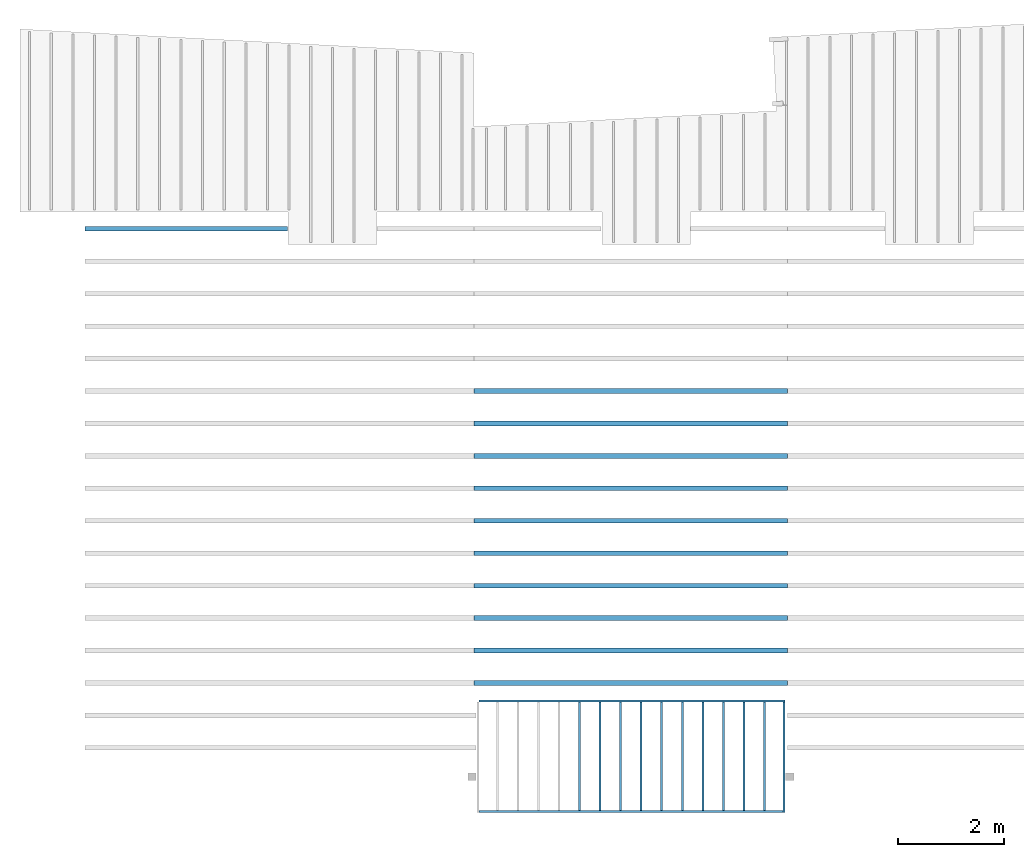
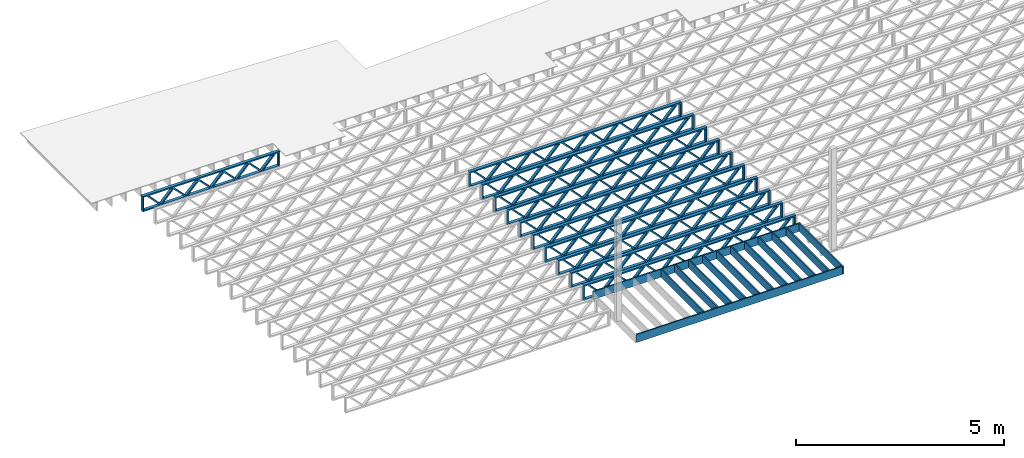
# One storey, part 2 of 13: 24 beams, 3 elements without a shape of their own.
"""IFC4 building model written with IfcOpenShell, lengths in feet."""

from ifc_helpers import new_model, entity, si_unit, converted_unit, derived_unit, direction, frame, frame_2d, origin, origin_2d_with_axis, place, context, subcontext, project, spatial, rectangle, extrude, source, transform, mapped, material, material_profile, profile_set, profile_usage, type_object, type_shapes, element, aggregate, save


model = new_model("IFC4")

# Units and contexts
model_context_1 = context("Model", 3, precision=0.0001, world=origin(), true_north=direction((6.12303176911189e-17, 1.0)))
model_context_2 = context("Model", 3, precision=0.0001, world=origin(), true_north=direction((6.12303176911189e-17, 1.0)))
body_context = subcontext(model_context_2, "Body", "Model", "MODEL_VIEW")
ifc_project = project(units=[converted_unit("LENGTHUNIT", "FOOT", entity("IfcRatioMeasure", 0.3048), si_unit("LENGTHUNIT", "METRE"), dimensions=[1, 0, 0, 0, 0, 0, 0]), converted_unit("AREAUNIT", "SQUARE FOOT", entity("IfcRatioMeasure", 0.09290304), si_unit("AREAUNIT", "SQUARE_METRE"), dimensions=[2, 0, 0, 0, 0, 0, 0]), converted_unit("VOLUMEUNIT", "CUBIC FOOT", entity("IfcRatioMeasure", 0.028316846592), si_unit("VOLUMEUNIT", "CUBIC_METRE"), dimensions=[3, 0, 0, 0, 0, 0, 0]), converted_unit("PLANEANGLEUNIT", "DEGREE", entity("IfcRatioMeasure", 0.0174532925199433), si_unit("PLANEANGLEUNIT", "RADIAN"), dimensions=[0, 0, 0, 0, 0, 0, 0]), si_unit("MASSUNIT", "GRAM", prefix="KILO"), derived_unit("MASSDENSITYUNIT", [(si_unit("MASSUNIT", "GRAM", prefix="KILO"), 1), (si_unit("LENGTHUNIT", "METRE"), -3)]), derived_unit("MOMENTOFINERTIAUNIT", [(si_unit("LENGTHUNIT", "METRE"), 4)]), si_unit("TIMEUNIT", "SECOND"), si_unit("FREQUENCYUNIT", "HERTZ"), si_unit("THERMODYNAMICTEMPERATUREUNIT", "DEGREE_CELSIUS"), derived_unit("THERMALTRANSMITTANCEUNIT", [(si_unit("MASSUNIT", "GRAM", prefix="KILO"), 1), (si_unit("THERMODYNAMICTEMPERATUREUNIT", "KELVIN"), -1), (si_unit("TIMEUNIT", "SECOND"), -3)]), derived_unit("VOLUMETRICFLOWRATEUNIT", [(si_unit("LENGTHUNIT", "METRE"), 3), (si_unit("TIMEUNIT", "SECOND"), -1)]), si_unit("ELECTRICCURRENTUNIT", "AMPERE"), si_unit("ELECTRICVOLTAGEUNIT", "VOLT"), si_unit("POWERUNIT", "WATT"), si_unit("FORCEUNIT", "NEWTON"), si_unit("ILLUMINANCEUNIT", "LUX"), si_unit("LUMINOUSFLUXUNIT", "LUMEN"), si_unit("LUMINOUSINTENSITYUNIT", "CANDELA"), derived_unit("USERDEFINED", [(si_unit("MASSUNIT", "GRAM", prefix="KILO"), -1), (si_unit("LENGTHUNIT", "METRE"), -2), (si_unit("TIMEUNIT", "SECOND"), 3), (si_unit("LUMINOUSFLUXUNIT", "LUMEN"), 1)]), derived_unit("LINEARVELOCITYUNIT", [(si_unit("LENGTHUNIT", "METRE"), 1), (si_unit("TIMEUNIT", "SECOND"), -1)]), si_unit("PRESSUREUNIT", "PASCAL"), derived_unit("USERDEFINED", [(si_unit("LENGTHUNIT", "METRE"), -2), (si_unit("MASSUNIT", "GRAM", prefix="KILO"), 1), (si_unit("TIMEUNIT", "SECOND"), -2)]), derived_unit("LINEARFORCEUNIT", [(si_unit("MASSUNIT", "GRAM", prefix="KILO"), 1), (si_unit("LENGTHUNIT", "METRE"), 1), (si_unit("TIMEUNIT", "SECOND"), -2), (si_unit("LENGTHUNIT", "METRE"), -1)]), derived_unit("PLANARFORCEUNIT", [(si_unit("MASSUNIT", "GRAM", prefix="KILO"), 1), (si_unit("LENGTHUNIT", "METRE"), 1), (si_unit("TIMEUNIT", "SECOND"), -2), (si_unit("LENGTHUNIT", "METRE"), -2)])], contexts=[model_context_1])

# Site, building, storey
site_placement = place(None, origin())
site = spatial("IfcSite", under=ifc_project, at=site_placement, CompositionType="ELEMENT")
building_placement = place(site_placement, origin())
building = spatial("IfcBuilding", under=site, at=building_placement, CompositionType="ELEMENT")
storey_placement = place(building_placement, frame((0.0, 0.0, 21.46875)))
storey = spatial("IfcBuildingStorey", under=building, at=storey_placement, Name="3RD FLOOR", CompositionType="ELEMENT", Elevation=21.46875)

# Assembly, beams
assembly_1_placement = place(storey_placement, origin())
assembly_1 = element("IfcElementAssembly", 1, at=assembly_1_placement, inside=storey, Name="Structural Beam System:Structural Framing System", ObjectType="Structural Beam System:Structural Framing System", AssemblyPlace="NOTDEFINED", PredefinedType="BEAM_GRID")
ifc_material_1 = material(Name="WOOD TRUSS", Category="Materials")
ifc_material_profile_1 = material_profile(ifc_material_1, rectangle(XDim=1.73473973950632, YDim=0.125, at=frame_2d((-1.11022302462516e-16, 8.32667268468867e-17), x_axis=(1.0, 0.0))))
ifc_material_profile_2 = material_profile(ifc_material_1, rectangle(XDim=1.73473973950633, YDim=0.125, at=frame_2d((-1.11022302462516e-16, 8.32667268468867e-17), x_axis=(1.0, 0.0))))
ifc_material_profile_3 = material_profile(ifc_material_1, rectangle(XDim=1.73473973950632, YDim=0.125, at=frame_2d((-5.55111512312578e-17, 1.38777878078145e-16), x_axis=(1.0, 0.0))))
ifc_material_profile_4 = material_profile(ifc_material_1, rectangle(XDim=1.73473973950633, YDim=0.125, at=frame_2d((-1.11022302462516e-16, 8.32667268468867e-17), x_axis=(1.0, 0.0))))
ifc_material_profile_5 = material_profile(ifc_material_1, rectangle(XDim=1.73473973950632, YDim=0.125, at=frame_2d((-1.11022302462516e-16, 8.32667268468867e-17), x_axis=(1.0, 0.0))))
ifc_material_profile_6 = material_profile(ifc_material_1, rectangle(XDim=1.73473973950633, YDim=0.125, at=frame_2d((-2.77555756156289e-16, 3.05311331771918e-16), x_axis=(1.0, 0.0))))
ifc_material_profile_7 = material_profile(ifc_material_1, rectangle(XDim=1.73473973950632, YDim=0.124999999999999, at=frame_2d((-3.88578058618805e-16, -2.4980018054066e-16), x_axis=(1.0, 0.0))))
ifc_material_profile_8 = material_profile(ifc_material_1, rectangle(XDim=1.73473973950633, YDim=0.125, at=frame_2d((2.77555756156289e-16, -3.05311331771918e-16), x_axis=(1.0, 0.0))))
ifc_material_profile_9 = material_profile(ifc_material_1, rectangle(XDim=1.73473973950632, YDim=0.124999999999999, at=frame_2d((-1.11022302462516e-16, 8.32667268468867e-17), x_axis=(1.0, 0.0))))
ifc_material_profile_10 = material_profile(ifc_material_1, rectangle(XDim=1.73473973950633, YDim=0.125, at=origin_2d_with_axis()))
ifc_material_profile_11 = material_profile(ifc_material_1, rectangle(XDim=0.124999999999982, YDim=0.291666666666668, at=origin_2d_with_axis()))
ifc_material_profile_12 = material_profile(ifc_material_1, rectangle(XDim=0.124999999999932, YDim=0.291666666666664, at=origin_2d_with_axis()))
ifc_material_profile_13 = material_profile(ifc_material_1, rectangle(XDim=1.25000000000002, YDim=0.29166666666667, at=origin_2d_with_axis()))
ifc_material_profile_14 = material_profile(ifc_material_1, rectangle(XDim=1.25000000000004, YDim=0.291666666666667, at=origin_2d_with_axis()))
ifc_profile_set_1 = profile_set([ifc_material_profile_1, ifc_material_profile_2, ifc_material_profile_3, ifc_material_profile_4, ifc_material_profile_5, ifc_material_profile_6, ifc_material_profile_7, ifc_material_profile_8, ifc_material_profile_9, ifc_material_profile_10, ifc_material_profile_11, ifc_material_profile_12, ifc_material_profile_13, ifc_material_profile_14])
ifc_profile_usage_1 = profile_usage(ifc_profile_set_1, cardinal=8)
beam_type_1 = type_object("IfcBeamType", PredefinedType="BEAM", material=ifc_profile_set_1)
shared_shape_1 = source(origin(), body_context, "Body", "SweptSolid", [
    extrude(rectangle(XDim=1.73473973950632, YDim=0.124999999999999, at=frame_2d((5.55111512312578e-16, 7.21644966006352e-16), x_axis=(1.0, 0.0))), frame((5.95847627016997, -0.145833333333334, 0.0), z_axis=(0.0, 1.0, 0.0), x_axis=(0.693383046997606, 0.0, 0.720569184836762)), (0.0, 0.0, 1.0), 0.291666666666667),
    extrude(rectangle(XDim=1.73473973950633, YDim=0.125, at=origin_2d_with_axis()), frame((4.7081903964967, -0.145833333333334, 0.0), z_axis=(0.0, 1.0, 0.0), x_axis=(0.69338304699761, 0.0, -0.720569184836758)), (0.0, 0.0, 1.0), 0.291666666666666),
    extrude(rectangle(XDim=1.73473973950632, YDim=0.125, at=frame_2d((2.22044604925031e-16, 3.88578058618805e-16), x_axis=(1.0, 0.0))), frame((3.29180960350347, -0.145833333333334, 0.0), z_axis=(0.0, 1.0, 0.0), x_axis=(0.693383046997606, 0.0, 0.720569184836762)), (0.0, 0.0, 1.0), 0.291666666666667),
    extrude(rectangle(XDim=1.73473973950633, YDim=0.125, at=frame_2d((1.11022302462516e-16, -8.32667268468867e-17), x_axis=(1.0, 0.0))), frame((2.0415237298302, -0.145833333333334, 0.0), z_axis=(0.0, 1.0, 0.0), x_axis=(0.69338304699761, 0.0, -0.720569184836758)), (0.0, 0.0, 1.0), 0.291666666666667),
    extrude(rectangle(XDim=1.73473973950632, YDim=0.125, at=frame_2d((-5.55111512312578e-17, 1.38777878078145e-16), x_axis=(1.0, 0.0))), frame((0.625142936836964, -0.145833333333334, 0.0), z_axis=(0.0, 1.0, 0.0), x_axis=(0.693383046997606, 0.0, 0.720569184836762)), (0.0, 0.0, 1.0), 0.291666666666667),
    extrude(rectangle(XDim=1.73473973950633, YDim=0.125, at=frame_2d((-1.11022302462516e-16, 8.32667268468867e-17), x_axis=(1.0, 0.0))), frame((-0.625142936836306, -0.145833333333334, 0.0), z_axis=(0.0, 1.0, 0.0), x_axis=(0.69338304699761, 0.0, -0.720569184836758)), (0.0, 0.0, 1.0), 0.291666666666667),
    extrude(rectangle(XDim=1.73473973950632, YDim=0.125, at=frame_2d((-1.11022302462516e-16, 8.32667268468867e-17), x_axis=(1.0, 0.0))), frame((-2.04152372982954, -0.145833333333334, 0.0), z_axis=(0.0, 1.0, 0.0), x_axis=(0.693383046997606, 0.0, 0.720569184836762)), (0.0, 0.0, 1.0), 0.291666666666667),
    extrude(rectangle(XDim=1.73473973950633, YDim=0.125, at=origin_2d_with_axis()), frame((-3.29180960350281, -0.145833333333334, 0.0), z_axis=(0.0, 1.0, 0.0), x_axis=(0.69338304699761, 0.0, -0.720569184836758)), (0.0, 0.0, 1.0), 0.291666666666667),
    extrude(rectangle(XDim=1.73473973950632, YDim=0.124999999999999, at=frame_2d((-1.11022302462516e-16, 8.32667268468867e-17), x_axis=(1.0, 0.0))), frame((-4.70819039649604, -0.145833333333334, 0.0), z_axis=(0.0, 1.0, 0.0), x_axis=(0.693383046997606, 0.0, 0.720569184836762)), (0.0, 0.0, 1.0), 0.291666666666667),
    extrude(rectangle(XDim=1.73473973950633, YDim=0.125, at=frame_2d((-5.55111512312578e-16, 6.38378239159465e-16), x_axis=(1.0, 0.0))), frame((-5.95847627016931, -0.145833333333334, 0.0), z_axis=(0.0, 1.0, 0.0), x_axis=(0.69338304699761, 0.0, -0.720569184836758)), (0.0, 0.0, 1.0), 0.291666666666666),
    extrude(rectangle(XDim=1.73473973950632, YDim=0.125, at=frame_2d((-7.21644966006352e-16, -5.82867087928207e-16), x_axis=(1.0, 0.0))), frame((8.62514293683647, -0.145833333333334, 0.0), z_axis=(0.0, 1.0, 0.0), x_axis=(0.693383046997607, 0.0, 0.720569184836761)), (0.0, 0.0, 1.0), 0.291666666666667),
    extrude(rectangle(XDim=1.73473973950633, YDim=0.125, at=origin_2d_with_axis()), frame((7.3748570631632, -0.145833333333334, 0.0), z_axis=(0.0, 1.0, 0.0), x_axis=(0.69338304699761, 0.0, -0.720569184836758)), (0.0, 0.0, 1.0), 0.291666666666666),
    extrude(rectangle(XDim=1.73473973950632, YDim=0.124999999999999, at=frame_2d((-1.11022302462516e-16, 8.32667268468867e-17), x_axis=(1.0, 0.0))), frame((-7.37485706316255, -0.145833333333334, 0.0), z_axis=(0.0, 1.0, 0.0), x_axis=(0.693383046997606, 0.0, 0.720569184836762)), (0.0, 0.0, 1.0), 0.291666666666667),
    extrude(rectangle(XDim=1.73473973950633, YDim=0.125, at=origin_2d_with_axis()), frame((-8.62514293683582, -0.145833333333334, 0.0), z_axis=(0.0, 1.0, 0.0), x_axis=(0.69338304699761, 0.0, -0.720569184836758)), (0.0, 0.0, 1.0), 0.291666666666666),
    extrude(rectangle(XDim=0.124999999999982, YDim=0.291666666666668, at=origin_2d_with_axis()), frame((-9.66666666666609, 0.0, 0.687500000000054), z_axis=(1.0, 0.0, 0.0), x_axis=(0.0, 0.0, -1.0)), (0.0, 0.0, 1.0), 19.3333333333322),
    extrude(rectangle(XDim=0.124999999999932, YDim=0.291666666666664, at=origin_2d_with_axis()), frame((-9.66666666666588, 0.0, -0.687499999999984), z_axis=(1.0, 0.0, 0.0), x_axis=(0.0, 0.0, -1.0)), (0.0, 0.0, 1.0), 19.333333333332),
    extrude(rectangle(XDim=1.25000000000002, YDim=0.29166666666667, at=origin_2d_with_axis()), frame((9.54166666666607, 0.0, 0.0), z_axis=(1.0, 0.0, 0.0), x_axis=(0.0, 0.0, -1.0)), (0.0, 0.0, 1.0), 0.12500000000002),
    extrude(rectangle(XDim=1.25000000000004, YDim=0.291666666666667, at=origin_2d_with_axis()), frame((-9.66666666666609, 0.0, 0.0), z_axis=(1.0, 0.0, 0.0), x_axis=(0.0, 0.0, -1.0)), (0.0, 0.0, 1.0), 0.125000000000023),
])
type_shapes(beam_type_1, [shared_shape_1])
beam_1_placement = place(assembly_1_placement, frame((-232.071493788724, 947.861934882651, -0.947916666666661)))
beam_1 = element("IfcBeam", 2, at=beam_1_placement, type_object=beam_type_1, material=ifc_profile_usage_1, PredefinedType="BEAM", context=body_context, shape_type="MappedRepresentation", body=[
    mapped(shared_shape_1, transform((0.0, 0.0, 0.0), scale=1.0)),
])
ifc_profile_usage_2 = profile_usage(ifc_profile_set_1, cardinal=8)
beam_2_placement = place(assembly_1_placement, frame((-232.071493788724, 945.861934882651, -0.947916666666661)))
beam_2 = element("IfcBeam", 3, at=beam_2_placement, type_object=beam_type_1, material=ifc_profile_usage_2, PredefinedType="BEAM", context=body_context, shape_type="MappedRepresentation", body=[
    mapped(shared_shape_1, transform((0.0, 0.0, 0.0), scale=1.0)),
])
ifc_profile_usage_3 = profile_usage(ifc_profile_set_1, cardinal=8)
beam_3_placement = place(assembly_1_placement, frame((-232.071493788724, 943.861934882651, -0.947916666666661)))
beam_3 = element("IfcBeam", 4, at=beam_3_placement, type_object=beam_type_1, material=ifc_profile_usage_3, PredefinedType="BEAM", context=body_context, shape_type="MappedRepresentation", body=[
    mapped(shared_shape_1, transform((0.0, 0.0, 0.0), scale=1.0)),
])
ifc_profile_usage_4 = profile_usage(ifc_profile_set_1, cardinal=8)
beam_4_placement = place(assembly_1_placement, frame((-232.071493788724, 941.861934882651, -0.947916666666661)))
beam_4 = element("IfcBeam", 5, at=beam_4_placement, type_object=beam_type_1, material=ifc_profile_usage_4, PredefinedType="BEAM", context=body_context, shape_type="MappedRepresentation", body=[
    mapped(shared_shape_1, transform((0.0, 0.0, 0.0), scale=1.0)),
])
ifc_profile_usage_5 = profile_usage(ifc_profile_set_1, cardinal=8)
beam_5_placement = place(assembly_1_placement, frame((-232.071493788724, 939.861934882651, -0.947916666666661)))
beam_5 = element("IfcBeam", 6, at=beam_5_placement, type_object=beam_type_1, material=ifc_profile_usage_5, PredefinedType="BEAM", context=body_context, shape_type="MappedRepresentation", body=[
    mapped(shared_shape_1, transform((0.0, 0.0, 0.0), scale=1.0)),
])
ifc_profile_usage_6 = profile_usage(ifc_profile_set_1, cardinal=8)
beam_6_placement = place(assembly_1_placement, frame((-232.071493788724, 937.861934882651, -0.947916666666661)))
beam_6 = element("IfcBeam", 7, at=beam_6_placement, type_object=beam_type_1, material=ifc_profile_usage_6, PredefinedType="BEAM", context=body_context, shape_type="MappedRepresentation", body=[
    mapped(shared_shape_1, transform((0.0, 0.0, 0.0), scale=1.0)),
])
ifc_profile_usage_7 = profile_usage(ifc_profile_set_1, cardinal=8)
beam_7_placement = place(assembly_1_placement, frame((-232.071493788724, 935.861934882651, -0.947916666666661)))
beam_7 = element("IfcBeam", 8, at=beam_7_placement, type_object=beam_type_1, material=ifc_profile_usage_7, PredefinedType="BEAM", context=body_context, shape_type="MappedRepresentation", body=[
    mapped(shared_shape_1, transform((0.0, 0.0, 0.0), scale=1.0)),
])
ifc_profile_usage_8 = profile_usage(ifc_profile_set_1, cardinal=8)
beam_8_placement = place(assembly_1_placement, frame((-232.071493788724, 933.861934882651, -0.947916666666661)))
beam_8 = element("IfcBeam", 9, at=beam_8_placement, type_object=beam_type_1, material=ifc_profile_usage_8, PredefinedType="BEAM", context=body_context, shape_type="MappedRepresentation", body=[
    mapped(shared_shape_1, transform((0.0, 0.0, 0.0), scale=1.0)),
])
ifc_profile_usage_9 = profile_usage(ifc_profile_set_1, cardinal=8)
beam_9_placement = place(assembly_1_placement, frame((-232.071493788724, 931.861934882651, -0.947916666666661)))
beam_9 = element("IfcBeam", 10, at=beam_9_placement, type_object=beam_type_1, material=ifc_profile_usage_9, PredefinedType="BEAM", context=body_context, shape_type="MappedRepresentation", body=[
    mapped(shared_shape_1, transform((0.0, 0.0, 0.0), scale=1.0)),
])
ifc_profile_usage_10 = profile_usage(ifc_profile_set_1, cardinal=8)
beam_10_placement = place(assembly_1_placement, frame((-232.071493788724, 929.861934882651, -0.947916666666661)))
beam_10 = element("IfcBeam", 11, at=beam_10_placement, type_object=beam_type_1, material=ifc_profile_usage_10, PredefinedType="BEAM", context=body_context, shape_type="MappedRepresentation", body=[
    mapped(shared_shape_1, transform((0.0, 0.0, 0.0), scale=1.0)),
])
aggregate(assembly_1, [beam_1, beam_2, beam_3, beam_4, beam_5, beam_6, beam_7, beam_8, beam_9, beam_10])

# Assembly, beam
assembly_2_placement = place(storey_placement, origin())
assembly_2 = element("IfcElementAssembly", 12, at=assembly_2_placement, inside=storey, Name="Structural Beam System:Structural Framing System", ObjectType="Structural Beam System:Structural Framing System", AssemblyPlace="NOTDEFINED", PredefinedType="BEAM_GRID")
ifc_profile_usage_11 = profile_usage(ifc_profile_set_1, cardinal=8)
beam_type_2 = type_object("IfcBeamType", PredefinedType="BEAM", material=ifc_profile_set_1)
shared_shape_2 = source(origin(), body_context, "Body", "SweptSolid", [
    extrude(rectangle(XDim=1.73473973950632, YDim=0.125, at=frame_2d((-1.11022302462516e-16, 8.32667268468867e-17), x_axis=(1.0, 0.0))), frame((2.91681155651982, -0.145833333333334, 0.0), z_axis=(0.0, 1.0, 0.0), x_axis=(0.693383046997606, 0.0, 0.720569184836762)), (0.0, 0.0, 1.0), 0.291666666666667),
    extrude(rectangle(XDim=1.73473973950633, YDim=0.125, at=frame_2d((-1.11022302462516e-16, 8.32667268468867e-17), x_axis=(1.0, 0.0))), frame((1.66652568284655, -0.145833333333334, 0.0), z_axis=(0.0, 1.0, 0.0), x_axis=(0.69338304699761, 0.0, -0.720569184836758)), (0.0, 0.0, 1.0), 0.291666666666667),
    extrude(rectangle(XDim=1.73473973950632, YDim=0.125, at=frame_2d((-5.55111512312578e-17, 1.38777878078145e-16), x_axis=(1.0, 0.0))), frame((0.625142936836964, -0.145833333333334, 0.0), z_axis=(0.0, 1.0, 0.0), x_axis=(0.693383046997606, 0.0, 0.720569184836762)), (0.0, 0.0, 1.0), 0.291666666666667),
    extrude(rectangle(XDim=1.73473973950633, YDim=0.125, at=frame_2d((-1.11022302462516e-16, 8.32667268468867e-17), x_axis=(1.0, 0.0))), frame((-0.625142936836307, -0.145833333333334, 0.0), z_axis=(0.0, 1.0, 0.0), x_axis=(0.69338304699761, 0.0, -0.720569184836758)), (0.0, 0.0, 1.0), 0.291666666666667),
    extrude(rectangle(XDim=1.73473973950632, YDim=0.125, at=frame_2d((-1.11022302462516e-16, 8.32667268468867e-17), x_axis=(1.0, 0.0))), frame((-1.66652568284589, -0.145833333333334, 0.0), z_axis=(0.0, 1.0, 0.0), x_axis=(0.693383046997606, 0.0, 0.720569184836762)), (0.0, 0.0, 1.0), 0.291666666666667),
    extrude(rectangle(XDim=1.73473973950633, YDim=0.125, at=frame_2d((-2.77555756156289e-16, 3.05311331771918e-16), x_axis=(1.0, 0.0))), frame((-2.91681155651916, -0.145833333333334, 0.0), z_axis=(0.0, 1.0, 0.0), x_axis=(0.69338304699761, 0.0, -0.720569184836758)), (0.0, 0.0, 1.0), 0.291666666666667),
    extrude(rectangle(XDim=1.73473973950632, YDim=0.124999999999999, at=frame_2d((-3.88578058618805e-16, -2.4980018054066e-16), x_axis=(1.0, 0.0))), frame((5.20848017620267, -0.145833333333334, 0.0), z_axis=(0.0, 1.0, 0.0), x_axis=(0.693383046997607, 0.0, 0.720569184836761)), (0.0, 0.0, 1.0), 0.291666666666666),
    extrude(rectangle(XDim=1.73473973950633, YDim=0.125, at=frame_2d((2.77555756156289e-16, -3.05311331771918e-16), x_axis=(1.0, 0.0))), frame((3.9581943025294, -0.145833333333334, 0.0), z_axis=(0.0, 1.0, 0.0), x_axis=(0.69338304699761, 0.0, -0.720569184836758)), (0.0, 0.0, 1.0), 0.291666666666666),
    extrude(rectangle(XDim=1.73473973950632, YDim=0.124999999999999, at=frame_2d((-1.11022302462516e-16, 8.32667268468867e-17), x_axis=(1.0, 0.0))), frame((-3.95819430252874, -0.145833333333334, 0.0), z_axis=(0.0, 1.0, 0.0), x_axis=(0.693383046997606, 0.0, 0.720569184836762)), (0.0, 0.0, 1.0), 0.291666666666667),
    extrude(rectangle(XDim=1.73473973950633, YDim=0.125, at=origin_2d_with_axis()), frame((-5.20848017620202, -0.145833333333334, 0.0), z_axis=(0.0, 1.0, 0.0), x_axis=(0.69338304699761, 0.0, -0.720569184836758)), (0.0, 0.0, 1.0), 0.291666666666666),
    extrude(rectangle(XDim=0.124999999999982, YDim=0.291666666666668, at=origin_2d_with_axis()), frame((-6.25000390603229, 0.0, 0.687500000000054), z_axis=(1.0, 0.0, 0.0), x_axis=(0.0, 0.0, -1.0)), (0.0, 0.0, 1.0), 12.5000078120646),
    extrude(rectangle(XDim=0.124999999999932, YDim=0.291666666666664, at=origin_2d_with_axis()), frame((-6.25000390603208, 0.0, -0.687499999999984), z_axis=(1.0, 0.0, 0.0), x_axis=(0.0, 0.0, -1.0)), (0.0, 0.0, 1.0), 12.5000078120644),
    extrude(rectangle(XDim=1.25000000000002, YDim=0.29166666666667, at=origin_2d_with_axis()), frame((6.12500390603227, 0.0, 0.0), z_axis=(1.0, 0.0, 0.0), x_axis=(0.0, 0.0, -1.0)), (0.0, 0.0, 1.0), 0.12500000000002),
    extrude(rectangle(XDim=1.25000000000004, YDim=0.291666666666667, at=origin_2d_with_axis()), frame((-6.25000390603229, 0.0, 0.0), z_axis=(1.0, 0.0, 0.0), x_axis=(0.0, 0.0, -1.0)), (0.0, 0.0, 1.0), 0.125000000000023),
])
type_shapes(beam_type_2, [shared_shape_2])
beam_11_placement = place(assembly_2_placement, frame((-259.488164391561, 957.861934882651, -0.947916666657854)))
beam_11 = element("IfcBeam", 13, at=beam_11_placement, type_object=beam_type_2, material=ifc_profile_usage_11, PredefinedType="BEAM", context=body_context, shape_type="MappedRepresentation", body=[
    mapped(shared_shape_2, transform((0.0, 0.0, 0.0), scale=1.0)),
])
aggregate(assembly_2, [beam_11])

# Assembly, beams
assembly_3_placement = place(storey_placement, origin())
assembly_3 = element("IfcElementAssembly", 14, at=assembly_3_placement, inside=storey, Name="Structural Beam System:Structural Framing System", ObjectType="Structural Beam System:Structural Framing System", AssemblyPlace="NOTDEFINED", PredefinedType="BEAM_GRID")
ifc_material_2 = material(Category="Materials")
ifc_material_profile_15 = material_profile(ifc_material_2, rectangle(XDim=0.770833333333333, YDim=0.124999999999994, at=frame_2d((-5.55111512312578e-17, 0.0), x_axis=(1.0, 0.0))))
ifc_profile_set_2 = profile_set([ifc_material_profile_15])
ifc_profile_usage_12 = profile_usage(ifc_profile_set_2, cardinal=8)
beam_type_3 = type_object("IfcBeamType", PredefinedType="BEAM", material=ifc_profile_set_2)
shared_shape_3 = source(origin(), body_context, "Body", "SweptSolid", [
    extrude(rectangle(XDim=0.770833333333333, YDim=0.124999999999994, at=frame_2d((-5.55111512312578e-17, 0.0), x_axis=(1.0, 0.0))), frame((-3.35416666666737, 0.0, 0.0), z_axis=(1.0, 0.0, 0.0), x_axis=(0.0, 0.0, -1.0)), (0.0, 0.0, 1.0), 6.70833333333462),
])
type_shapes(beam_type_3, [shared_shape_3])
beam_12_placement = place(assembly_3_placement, frame((-235.24032967825, 925.341101549317, -0.645833333333474), z_axis=(0.0, 0.0, 1.0), x_axis=(0.0, 1.0, 0.0)))
beam_12 = element("IfcBeam", 15, at=beam_12_placement, type_object=beam_type_3, material=ifc_profile_usage_12, PredefinedType="BEAM", context=body_context, shape_type="MappedRepresentation", body=[
    mapped(shared_shape_3, transform((0.0, 0.0, 0.0), scale=1.0)),
])
ifc_profile_usage_13 = profile_usage(ifc_profile_set_2, cardinal=8)
beam_13_placement = place(assembly_3_placement, frame((-233.973445997692, 925.341101549317, -0.645833333333474), z_axis=(0.0, 0.0, 1.0), x_axis=(0.0, 1.0, 0.0)))
beam_13 = element("IfcBeam", 16, at=beam_13_placement, type_object=beam_type_3, material=ifc_profile_usage_13, PredefinedType="BEAM", context=body_context, shape_type="MappedRepresentation", body=[
    mapped(shared_shape_3, transform((0.0, 0.0, 0.0), scale=1.0)),
])
ifc_profile_usage_14 = profile_usage(ifc_profile_set_2, cardinal=8)
beam_14_placement = place(assembly_3_placement, frame((-232.706562317134, 925.341101549317, -0.645833333333474), z_axis=(0.0, 0.0, 1.0), x_axis=(0.0, 1.0, 0.0)))
beam_14 = element("IfcBeam", 17, at=beam_14_placement, type_object=beam_type_3, material=ifc_profile_usage_14, PredefinedType="BEAM", context=body_context, shape_type="MappedRepresentation", body=[
    mapped(shared_shape_3, transform((0.0, 0.0, 0.0), scale=1.0)),
])
ifc_profile_usage_15 = profile_usage(ifc_profile_set_2, cardinal=8)
beam_15_placement = place(assembly_3_placement, frame((-231.439678636575, 925.341101549318, -0.645833333333435), z_axis=(0.0, 0.0, 1.0), x_axis=(0.0, 1.0, 0.0)))
beam_15 = element("IfcBeam", 18, at=beam_15_placement, type_object=beam_type_3, material=ifc_profile_usage_15, PredefinedType="BEAM", context=body_context, shape_type="MappedRepresentation", body=[
    mapped(shared_shape_3, transform((0.0, 0.0, 0.0), scale=1.0)),
])
ifc_profile_usage_16 = profile_usage(ifc_profile_set_2, cardinal=8)
beam_16_placement = place(assembly_3_placement, frame((-230.172794956017, 925.341101549318, -0.645833333333474), z_axis=(0.0, 0.0, 1.0), x_axis=(0.0, 1.0, 0.0)))
beam_16 = element("IfcBeam", 19, at=beam_16_placement, type_object=beam_type_3, material=ifc_profile_usage_16, PredefinedType="BEAM", context=body_context, shape_type="MappedRepresentation", body=[
    mapped(shared_shape_3, transform((0.0, 0.0, 0.0), scale=1.0)),
])
ifc_profile_usage_17 = profile_usage(ifc_profile_set_2, cardinal=8)
beam_17_placement = place(assembly_3_placement, frame((-228.905911275459, 925.341101549318, -0.645833333333474), z_axis=(0.0, 0.0, 1.0), x_axis=(0.0, 1.0, 0.0)))
beam_17 = element("IfcBeam", 20, at=beam_17_placement, type_object=beam_type_3, material=ifc_profile_usage_17, PredefinedType="BEAM", context=body_context, shape_type="MappedRepresentation", body=[
    mapped(shared_shape_3, transform((0.0, 0.0, 0.0), scale=1.0)),
])
ifc_profile_usage_18 = profile_usage(ifc_profile_set_2, cardinal=8)
beam_18_placement = place(assembly_3_placement, frame((-227.6390275949, 925.341101549318, -0.645833333333474), z_axis=(0.0, 0.0, 1.0), x_axis=(0.0, 1.0, 0.0)))
beam_18 = element("IfcBeam", 21, at=beam_18_placement, type_object=beam_type_3, material=ifc_profile_usage_18, PredefinedType="BEAM", context=body_context, shape_type="MappedRepresentation", body=[
    mapped(shared_shape_3, transform((0.0, 0.0, 0.0), scale=1.0)),
])
ifc_profile_usage_19 = profile_usage(ifc_profile_set_2, cardinal=8)
beam_19_placement = place(assembly_3_placement, frame((-226.372143914342, 925.341101549318, -0.645833333333474), z_axis=(0.0, 0.0, 1.0), x_axis=(0.0, 1.0, 0.0)))
beam_19 = element("IfcBeam", 22, at=beam_19_placement, type_object=beam_type_3, material=ifc_profile_usage_19, PredefinedType="BEAM", context=body_context, shape_type="MappedRepresentation", body=[
    mapped(shared_shape_3, transform((0.0, 0.0, 0.0), scale=1.0)),
])
ifc_profile_usage_20 = profile_usage(ifc_profile_set_2, cardinal=8)
beam_20_placement = place(assembly_3_placement, frame((-225.105260233784, 925.341101549318, -0.645833333333474), z_axis=(0.0, 0.0, 1.0), x_axis=(0.0, 1.0, 0.0)))
beam_20 = element("IfcBeam", 23, at=beam_20_placement, type_object=beam_type_3, material=ifc_profile_usage_20, PredefinedType="BEAM", context=body_context, shape_type="MappedRepresentation", body=[
    mapped(shared_shape_3, transform((0.0, 0.0, 0.0), scale=1.0)),
])
ifc_profile_usage_21 = profile_usage(ifc_profile_set_2, cardinal=8)
beam_21_placement = place(assembly_3_placement, frame((-223.838376553225, 925.341101549319, -0.645833333333474), z_axis=(0.0, 0.0, 1.0), x_axis=(0.0, 1.0, 0.0)))
beam_21 = element("IfcBeam", 24, at=beam_21_placement, type_object=beam_type_3, material=ifc_profile_usage_21, PredefinedType="BEAM", context=body_context, shape_type="MappedRepresentation", body=[
    mapped(shared_shape_3, transform((0.0, 0.0, 0.0), scale=1.0)),
])
aggregate(assembly_3, [beam_12, beam_13, beam_14, beam_15, beam_16, beam_17, beam_18, beam_19, beam_20, beam_21])

# Beams
ifc_profile_usage_22 = profile_usage(ifc_profile_set_2, cardinal=8)
beam_type_4 = type_object("IfcBeamType", PredefinedType="BEAM", material=ifc_profile_set_2)
shared_shape_4 = source(origin(), body_context, "Body", "SweptSolid", [
    extrude(rectangle(XDim=0.770833333333333, YDim=0.124999999999994, at=origin_2d_with_axis()), frame((-9.49999887751909, 0.0, 0.0), z_axis=(1.0, 0.0, 0.0), x_axis=(0.0, 0.0, -1.0)), (0.0, 0.0, 1.0), 18.8749977550383),
])
type_shapes(beam_type_4, [shared_shape_4])
beam_22_placement = place(storey_placement, frame((-232.071494726732, 928.757768215985, -0.645833333333506), z_axis=(0.0, 0.0, 1.0), x_axis=(-1.0, 0.0, 0.0)))
element("IfcBeam", 25, at=beam_22_placement, inside=storey, type_object=beam_type_4, material=ifc_profile_usage_22, PredefinedType="BEAM", context=body_context, shape_type="MappedRepresentation", body=[
    mapped(shared_shape_4, transform((0.0, 0.0, 0.0), scale=1.0)),
])
ifc_profile_usage_23 = profile_usage(ifc_profile_set_2, cardinal=8)
beam_type_5 = type_object("IfcBeamType", PredefinedType="BEAM", material=ifc_profile_set_2)
shared_shape_5 = source(origin(), body_context, "Body", "SweptSolid", [
    extrude(rectangle(XDim=0.770833333333333, YDim=0.124999999999994, at=origin_2d_with_axis()), frame((-3.47916666666737, 0.0, 0.0), z_axis=(1.0, 0.0, 0.0), x_axis=(0.0, 0.0, -1.0)), (0.0, 0.0, 1.0), 6.83333333333471),
])
type_shapes(beam_type_5, [shared_shape_5])
beam_23_placement = place(storey_placement, frame((-222.633995849213, 925.341101549319, -0.645833333333513), z_axis=(0.0, 0.0, 1.0), x_axis=(0.0, 1.0, 0.0)))
element("IfcBeam", 26, at=beam_23_placement, inside=storey, type_object=beam_type_5, material=ifc_profile_usage_23, PredefinedType="BEAM", context=body_context, shape_type="MappedRepresentation", body=[
    mapped(shared_shape_5, transform((0.0, 0.0, 0.0), scale=1.0)),
])
ifc_material_3 = material(Name="BRAKE METAL FLASHING AT PERIMETER 2X LEDGER", Category="Materials")
ifc_material_profile_16 = material_profile(ifc_material_3, rectangle(XDim=0.770833333333333, YDim=0.124999999999994, at=frame_2d((-1.11022302462516e-16, 0.0), x_axis=(1.0, 0.0))), Name="BRAKE METAL FLASHING AT PERIMETER 2X LEDGER")
ifc_profile_set_3 = profile_set([ifc_material_profile_16], Name="BRAKE METAL FLASHING AT PERIMETER 2X LEDGER")
ifc_profile_usage_24 = profile_usage(ifc_profile_set_3, cardinal=8)
beam_type_6 = type_object("IfcBeamType", PredefinedType="BEAM", material=ifc_profile_set_3)
shared_shape_6 = source(origin(), body_context, "Body", "SweptSolid", [
    extrude(rectangle(XDim=0.770833333333333, YDim=0.124999999999994, at=origin_2d_with_axis()), frame((-9.37499887751909, 0.0, 0.0), z_axis=(1.0, 0.0, 0.0), x_axis=(0.0, 0.0, -1.0)), (0.0, 0.0, 1.0), 18.7499977550382),
])
type_shapes(beam_type_6, [shared_shape_6])
beam_24_placement = place(storey_placement, frame((-232.071494726732, 921.92443488265, -0.645833333333496), z_axis=(0.0, 0.0, 1.0), x_axis=(-1.0, 0.0, 0.0)))
element("IfcBeam", 27, at=beam_24_placement, inside=storey, type_object=beam_type_6, material=ifc_profile_usage_24, PredefinedType="BEAM", context=body_context, shape_type="MappedRepresentation", body=[
    mapped(shared_shape_6, transform((0.0, 0.0, 0.0), scale=1.0)),
])

save(model, "model.ifc")
